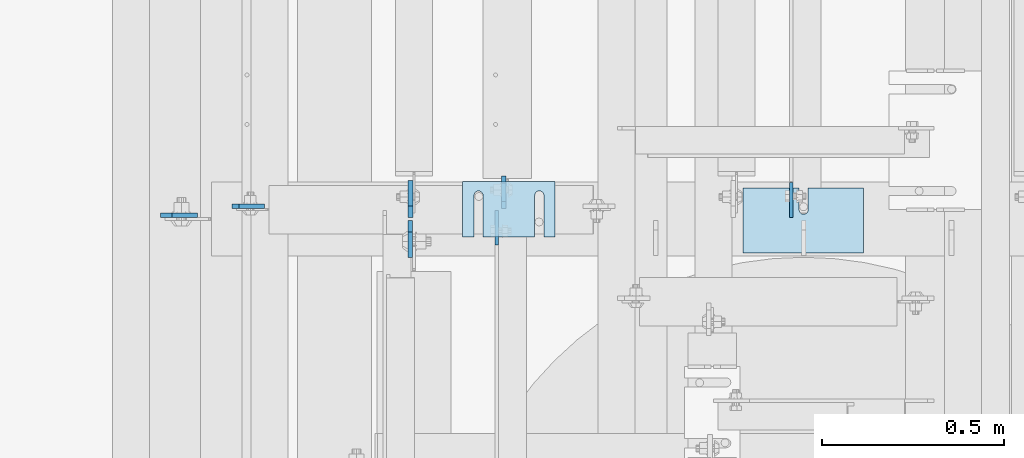
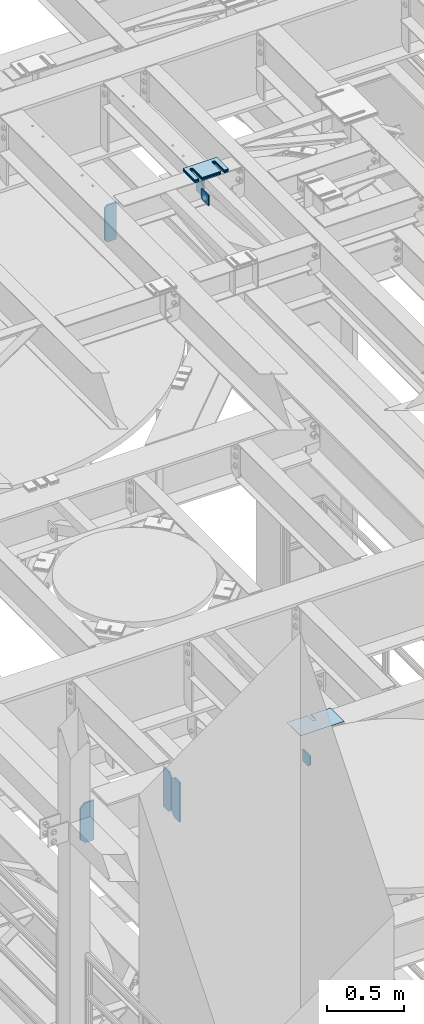
# One storey, part 1697 of 1876: 14 plates, 11 elements without a shape of their own.
"""IFC2X3 building model written with IfcOpenShell, lengths in millimetres."""

from ifc_helpers import new_model, si_unit, frame, origin_with_axes, place, context, subcontext, project, spatial, faceted_brep, material, type_object, element, aggregate, save


model = new_model("IFC2X3")

# Units and contexts
model_context = context("Model", 3, precision=1e-05, world=origin_with_axes())
body_context = subcontext(model_context, "Body", "Model", "MODEL_VIEW")
ifc_project = project(units=[si_unit("LENGTHUNIT", "METRE", prefix="MILLI"), si_unit("AREAUNIT", "SQUARE_METRE"), si_unit("VOLUMEUNIT", "CUBIC_METRE"), si_unit("MASSUNIT", "GRAM", prefix="KILO"), si_unit("TIMEUNIT", "SECOND"), si_unit("PLANEANGLEUNIT", "RADIAN"), si_unit("SOLIDANGLEUNIT", "STERADIAN"), si_unit("THERMODYNAMICTEMPERATUREUNIT", "DEGREE_CELSIUS"), si_unit("LUMINOUSINTENSITYUNIT", "LUMEN")], contexts=[model_context])

# Site, building, storey
site_placement = place(None, origin_with_axes())
site = spatial("IfcSite", under=ifc_project, at=site_placement, CompositionType="ELEMENT")
building_placement = place(site_placement, origin_with_axes())
building = spatial("IfcBuilding", under=site, at=building_placement, Name="Undefined", CompositionType="ELEMENT")
storey_placement = place(building_placement, origin_with_axes())
storey = spatial("IfcBuildingStorey", under=building, at=storey_placement, Name="Undefined", CompositionType="ELEMENT", Elevation=0.0)

# Assembly, plate
assembly_1_placement = place(storey_placement, origin_with_axes())
assembly_1 = element("IfcElementAssembly", 1, at=assembly_1_placement, inside=storey, Name="BEAM", AssemblyPlace="NOTDEFINED", PredefinedType="RIGID_FRAME")
ifc_material = material(Name="STEEL/A36")
plate_type_1 = type_object("IfcPlateType", PredefinedType="NOTDEFINED")
plate_1_placement = place(assembly_1_placement, frame((3338.51211036534, 6347.93791797889, 12976.225), z_axis=(0.0, -1.0, 0.0), x_axis=(0.0, 0.0, 1.0)))
plate_1 = element("IfcPlate", 2, at=plate_1_placement, type_object=plate_type_1, material=ifc_material, Name="PLATE", context=body_context, shape_type="Brep", body=[
    faceted_brep([(0.0, -4.76249999999982, 0.0), (0.0, -4.76249999999982, 71.7566699981689), (0.0, 4.76249999999982, 71.7566699981689), (0.0, 4.76249999999982, 0.0), (25.3999996185303, -4.76249999999982, 97.1566696166992), (25.3999996185303, 4.76249999999982, 97.1566696166992), (92.3540878295898, -4.76249999999982, 97.1566696166992), (92.3540878295898, 4.76249999999982, 97.1566696166992), (92.3540878295898, -4.76249999999982, 0.0), (92.3540878295898, 4.76249999999982, 0.0)], [[[0, 1, 2, 3]], [[1, 4, 5, 2]], [[4, 6, 7, 5]], [[6, 8, 9, 7]], [[8, 0, 3, 9]], [[5, 7, 9, 3, 2]], [[8, 6, 4, 1, 0]]]),
])

assembly_2_placement = place(storey_placement, origin_with_axes())
assembly_2 = element("IfcElementAssembly", 3, at=assembly_2_placement, inside=storey, Name="BEAM", AssemblyPlace="NOTDEFINED", PredefinedType="RIGID_FRAME")
plate_type_2 = type_object("IfcPlateType", PredefinedType="NOTDEFINED")
plate_2_placement = place(assembly_2_placement, frame((2529.26824474912, 6176.14514562684, 17784.7625), z_axis=(0.0, 0.0, 1.0), x_axis=(0.0, 1.0, 0.0)))
plate_2 = element("IfcPlate", 4, at=plate_2_placement, type_object=plate_type_2, material=ifc_material, Name="PLATE", context=body_context, shape_type="Brep", body=[
    faceted_brep([(0.0, -4.76249999999982, 0.0), (0.0, -4.76249999999982, 81.2718963623047), (0.0, 4.76249999999982, 81.2718963623047), (0.0, 4.76249999999982, 0.0), (93.8565444946289, -4.76249999999982, 81.2718963623047), (93.8565444946289, 4.76249999999982, 81.2718963623047), (93.8565444946289, -4.76249999999982, 12.6999998092651), (93.8565444946289, 4.76249999999982, 12.6999998092651), (81.1565446853638, -4.76249999999982, 0.0), (81.1565446853638, 4.76249999999982, 0.0)], [[[0, 1, 2, 3]], [[1, 4, 5, 2]], [[4, 6, 7, 5]], [[6, 8, 9, 7]], [[8, 0, 3, 9]], [[5, 7, 9, 3, 2]], [[8, 6, 4, 1, 0]]]),
])

assembly_3_placement = place(storey_placement, origin_with_axes())
assembly_3 = element("IfcElementAssembly", 5, at=assembly_3_placement, inside=storey, Name="BEAM", AssemblyPlace="NOTDEFINED", PredefinedType="RIGID_FRAME")
plate_type_3 = type_object("IfcPlateType", PredefinedType="NOTDEFINED")
plate_3_placement = place(assembly_3_placement, frame((1801.8125, 6282.7016907692, 17681.575), z_axis=(0.0, 0.0, 1.0), x_axis=(1.0, 0.0, 0.0)))
plate_3 = element("IfcPlate", 6, at=plate_3_placement, type_object=plate_type_3, material=ifc_material, Name="PLATE", context=body_context, shape_type="Brep", body=[
    faceted_brep([(0.0, -6.35000000000196, 19.0499992370605), (9.09494701772928e-13, -6.34999999999832, 273.050006866455), (-2.72848410531878e-12, 6.34999999999923, 273.050006866455), (0.0, 6.35000000000105, 19.0499992370605), (19.0499992370578, -6.35000000000696, 292.100006103516), (19.049999237056, 6.3499999999915, 292.100006103516), (88.9000015258789, -6.35000000000036, 292.100006103516), (88.9000015258789, 6.35000000000036, 292.100006103516), (88.9000015258789, -6.34999999999991, 0.0), (88.9000015258789, 6.34999999999991, 0.0), (19.0499992370642, -6.35000000000105, 0.0), (19.0499992370633, 6.35000000000105, 0.0)], [[[0, 1, 2, 3]], [[1, 4, 5, 2]], [[4, 6, 7, 5]], [[6, 8, 9, 7]], [[8, 10, 11, 9]], [[10, 0, 3, 11]], [[5, 7, 9, 11, 3, 2]], [[10, 8, 6, 4, 1, 0]]]),
])
aggregate(assembly_3, [plate_3])

# Plate
plate_4_placement = place(assembly_2_placement, frame((2548.05977180008, 6276.35197391557, 17786.35), z_axis=(0.0, 0.0, 1.0), x_axis=(-4.46050000005016e-05, 0.999999999005197, 0.0)))
plate_4 = element("IfcPlate", 7, at=plate_4_placement, type_object=plate_type_3, material=ifc_material, Name="PLATE", context=body_context, shape_type="Brep", body=[
    faceted_brep([(0.0, -6.35000000000196, 19.0499992370605), (0.0, -6.34999999999991, 169.862506866455), (0.0, 6.34999999999991, 169.862506866455), (0.0, 6.35000000000105, 19.0499992370605), (19.0499992370605, -6.34999999999991, 188.912506103516), (19.0499992370605, 6.34999999999991, 188.912506103516), (69.8500022888184, -6.34999999999991, 188.912506103516), (69.8500022888184, 6.34999999999991, 188.912506103516), (88.9000015258789, -6.34999999999991, 169.862506866455), (88.9000015258789, 6.34999999999991, 169.862506866455), (88.9000015258789, -6.34999999999991, 0.0), (88.9000015258789, 6.34999999999991, 0.0), (19.0499992370642, -6.35000000000105, 0.0), (19.0499992370633, 6.35000000000105, 0.0)], [[[0, 1, 2, 3]], [[1, 4, 5, 2]], [[4, 6, 7, 5]], [[6, 8, 9, 7]], [[8, 10, 11, 9]], [[10, 12, 13, 11]], [[12, 0, 3, 13]], [[5, 7, 9, 11, 13, 3, 2]], [[12, 10, 8, 6, 4, 1, 0]]]),
])

aggregate(assembly_2, [plate_2, plate_4])

plate_type_4 = type_object("IfcPlateType", PredefinedType="NOTDEFINED")
plate_5_placement = place(assembly_1_placement, frame((2291.55624990463, 6242.84375, 12977.8125), z_axis=(0.0, 0.0, 1.0), x_axis=(0.0, -1.0, 0.0)))
plate_5 = element("IfcPlate", 8, at=plate_5_placement, type_object=plate_type_4, material=ifc_material, Name="PLATE", context=body_context, shape_type="Brep", body=[
    faceted_brep([(0.0, -6.34999999999991, 31.75), (-1.81898940354586e-12, -6.34999999999991, 284.162506103516), (1.81898940354586e-12, 6.35000000000173, 284.162506103516), (0.0, 6.34999999999991, 31.75), (31.7499999999927, -6.34999999999991, 315.912506103516), (31.7499999999982, 6.35000000000309, 315.912506103516), (101.599998474121, -6.35000000000036, 315.912506103516), (101.599998474121, 6.35000000000036, 315.912506103516), (101.599998474121, -6.35000000000036, 0.0), (101.599998474121, 6.35000000000036, 0.0), (31.75, -6.34999999999991, 0.0), (31.75, 6.34999999999991, 0.0)], [[[0, 1, 2, 3]], [[1, 4, 5, 2]], [[4, 6, 7, 5]], [[6, 8, 9, 7]], [[8, 10, 11, 9]], [[10, 0, 3, 11]], [[5, 7, 9, 11, 3, 2]], [[10, 8, 6, 4, 1, 0]]]),
])

# Assembly, plate
assembly_4_placement = place(storey_placement, origin_with_axes())
assembly_4 = element("IfcElementAssembly", 9, at=assembly_4_placement, inside=storey, Name="BEAM", AssemblyPlace="NOTDEFINED", PredefinedType="RIGID_FRAME")
plate_6_placement = place(assembly_4_placement, frame((1605.75625, 6257.13125009537, 12974.6375), z_axis=(0.0, 0.0, 1.0), x_axis=(1.0, 0.0, 0.0)))
plate_6 = element("IfcPlate", 10, at=plate_6_placement, type_object=plate_type_4, material=ifc_material, Name="PLATE", context=body_context, shape_type="Brep", body=[
    faceted_brep([(0.0, -6.34999999999991, 31.75), (-1.81898940354586e-12, -6.34999999999991, 284.162506103516), (1.81898940354586e-12, 6.35000000000173, 284.162506103516), (0.0, 6.34999999999991, 31.75), (31.7499999999927, -6.34999999999991, 315.912506103516), (31.7499999999982, 6.35000000000309, 315.912506103516), (101.599998474121, -6.35000000000036, 315.912506103516), (101.599998474121, 6.35000000000036, 315.912506103516), (101.599998474121, -6.35000000000036, 0.0), (101.599998474121, 6.35000000000036, 0.0), (31.75, -6.34999999999991, 0.0), (31.75, 6.34999999999991, 0.0)], [[[0, 1, 2, 3]], [[1, 4, 5, 2]], [[4, 6, 7, 5]], [[6, 8, 9, 7]], [[8, 10, 11, 9]], [[10, 0, 3, 11]], [[5, 7, 9, 11, 3, 2]], [[10, 8, 6, 4, 1, 0]]]),
])
aggregate(assembly_4, [plate_6])

# Plate
plate_7_placement = place(assembly_1_placement, frame((2292.34999990463, 6250.78125, 12977.8125), z_axis=(0.0, 0.0, 1.0), x_axis=(0.0, 1.0, 0.0)))
plate_7 = element("IfcPlate", 11, at=plate_7_placement, type_object=plate_type_4, material=ifc_material, Name="PLATE", context=body_context, shape_type="Brep", body=[
    faceted_brep([(0.0, -6.34999999999991, 31.75), (-1.81898940354586e-12, -6.34999999999991, 284.162506103516), (1.81898940354586e-12, 6.35000000000173, 284.162506103516), (0.0, 6.34999999999991, 31.75), (31.7499999999927, -6.34999999999991, 315.912506103516), (31.7499999999982, 6.35000000000309, 315.912506103516), (101.599998474121, -6.35000000000036, 315.912506103516), (101.599998474121, 6.35000000000036, 315.912506103516), (101.599998474121, -6.35000000000036, 0.0), (101.599998474121, 6.35000000000036, 0.0), (31.75, -6.34999999999991, 0.0), (31.75, 6.34999999999991, 0.0)], [[[0, 1, 2, 3]], [[1, 4, 5, 2]], [[4, 6, 7, 5]], [[6, 8, 9, 7]], [[8, 10, 11, 9]], [[10, 0, 3, 11]], [[5, 7, 9, 11, 3, 2]], [[10, 8, 6, 4, 1, 0]]]),
])

aggregate(assembly_1, [plate_1, plate_5, plate_7])

# Assembly, plate
assembly_5_placement = place(storey_placement, origin_with_axes())
assembly_5 = element("IfcElementAssembly", 12, at=assembly_5_placement, inside=storey, Name="SHIM PLATE", AssemblyPlace="NOTDEFINED", PredefinedType="RIGID_FRAME")
plate_type_5 = type_object("IfcPlateType", PredefinedType="NOTDEFINED")
plate_8_placement = place(assembly_5_placement, frame((2689.6055343235, 6349.99749088431, 18009.3925), z_axis=(0.0, -1.0, 0.0), x_axis=(-1.0, 0.0, 0.0)))
plate_8 = element("IfcPlate", 13, at=plate_8_placement, type_object=plate_type_5, material=ifc_material, Name="SHIM PLATE", context=body_context, shape_type="Brep", body=[
    faceted_brep([(30.8791924037423, -0.793499999999767, 152.398895263674), (30.8814140421409, -0.793499999999767, 38.0994505407325), (30.8814140421409, 0.793499999999767, 38.0994505407325), (30.8791924037423, 0.793499999999767, 152.398895263674), (32.5828868936751, -0.793499999999767, 31.7494480341243), (32.5828868936751, 0.793499999999767, 31.7494480341243), (37.2314075583954, -0.793499999999767, 27.1009216732054), (37.2314075583954, 0.793499999999767, 27.1009216732054), (43.5814079800521, -0.793499999999767, 25.3994410405157), (43.5814079800521, 0.793499999999767, 25.3994410405157), (49.9314097200559, -0.793499999999767, 27.1009167530574), (49.9314097200559, 0.793499999999767, 27.1009167530574), (54.5799339865616, -0.793499999999767, 31.7494395121785), (54.5799339865616, 0.793499999999767, 31.7494395121785), (56.2814117582284, -0.793499999999767, 38.0994407004391), (56.2814117582284, 0.793499999999767, 38.0994407004391), (56.2791901197206, -0.793499999999767, 152.398894414155), (56.2791901197206, 0.793499999999767, 152.398895263676), (9.09494701772928e-13, -0.793499999999767, 0.0), (1.98268335225293e-05, -0.793499999999767, 152.398895263672), (1.98268335225293e-05, 0.793499999999767, 152.398895263672), (9.09494701772928e-13, 0.793499999999767, 0.0), (253.999542236328, -0.793499999999767, 6.16182660451159e-11), (253.999542236328, 0.793499999999767, 6.16182660451159e-11), (253.999557495107, -0.793499999999767, 152.398895263688), (253.999557495107, 0.793499999999767, 152.398895263688), (223.116882380463, 0.793499999999767, 152.398895263686), (223.116882380463, -0.793499999999767, 152.398895415181), (223.119104018971, 0.793499999999767, 38.0994417014649), (223.119104018971, -0.793499999999767, 38.0994417014649), (221.417626247304, 0.793499999999767, 31.7494405132047), (221.417626247304, -0.793499999999767, 31.7494405132047), (216.769101980798, 0.793499999999767, 27.1009177540836), (216.769101980798, -0.793499999999767, 27.1009177540836), (210.419100240794, 0.793499999999767, 25.399442041542), (210.419100240794, -0.793499999999767, 25.399442041542), (204.069099819138, 0.793499999999767, 27.1009226742317), (204.069099819138, -0.793499999999767, 27.1009226742317), (199.420579154417, 0.793499999999767, 31.7494490351505), (199.420579154417, -0.793499999999767, 31.7494490351505), (197.719106302883, 0.793499999999767, 38.0994515417583), (197.719106302883, -0.793499999999767, 38.0994515417583), (197.716884664484, -0.793499999999767, 152.398895263684), (197.716884664484, 0.793499999999767, 152.398895263684)], [[[0, 1, 2, 3]], [[4, 5, 2, 1]], [[6, 7, 5, 4]], [[8, 9, 7, 6]], [[10, 11, 9, 8]], [[12, 13, 11, 10]], [[14, 15, 13, 12]], [[16, 17, 15, 14]], [[18, 19, 20, 21]], [[22, 18, 21, 23]], [[24, 22, 23, 25]], [[24, 25, 26, 27]], [[27, 26, 28, 29]], [[29, 28, 30, 31]], [[31, 30, 32, 33]], [[33, 32, 34, 35]], [[35, 34, 36, 37]], [[37, 36, 38, 39]], [[39, 38, 40, 41]], [[42, 41, 40, 43]], [[12, 10, 8, 6, 4, 1, 0, 19, 18, 22, 24, 27, 29, 31, 33, 35, 37, 39, 41, 42, 16, 14]], [[20, 19, 0, 3]], [[43, 40, 38, 36, 34, 32, 30, 28, 26, 25, 23, 21, 20, 3, 2, 5, 7, 9, 11, 13, 15, 17]], [[42, 43, 17, 16]]]),
])
aggregate(assembly_5, [plate_8])

assembly_6_placement = place(storey_placement, origin_with_axes())
assembly_6 = element("IfcElementAssembly", 14, at=assembly_6_placement, inside=storey, Name="SHIM PLATE", AssemblyPlace="NOTDEFINED", PredefinedType="RIGID_FRAME")
plate_type_6 = type_object("IfcPlateType", PredefinedType="NOTDEFINED")
plate_9_placement = place(assembly_6_placement, frame((2689.6055343235, 6349.99749088454, 18007.0115), z_axis=(0.0, -1.0, 0.0), x_axis=(-1.0, 0.0, 0.0)))
plate_9 = element("IfcPlate", 15, at=plate_9_placement, type_object=plate_type_6, material=ifc_material, Name="SHIM PLATE", context=body_context, shape_type="Brep", body=[
    faceted_brep([(30.8791924037423, -1.58750000000146, 152.398895263674), (30.8814140421409, -1.58750000000146, 38.0994505407325), (30.8814140421409, 1.58750000000146, 38.0994505407325), (30.8791924037423, 1.58750000000146, 152.398895263674), (32.5828868936751, -1.58750000000146, 31.7494480341243), (32.5828868936751, 1.58750000000146, 31.7494480341243), (37.2314075583954, -1.58750000000146, 27.1009216732054), (37.2314075583954, 1.58750000000146, 27.1009216732054), (43.5814079800521, -1.58750000000146, 25.3994410405157), (43.5814079800521, 1.58750000000146, 25.3994410405157), (49.9314097200559, -1.58750000000146, 27.1009167530574), (49.9314097200559, 1.58750000000146, 27.1009167530574), (54.5799339865616, -1.58750000000146, 31.7494395121785), (54.5799339865616, 1.58750000000146, 31.7494395121785), (56.2814117582284, -1.58750000000146, 38.0994407004391), (56.2814117582284, 1.58750000000146, 38.0994407004391), (56.2791901197206, -1.58750000000146, 152.398894414155), (56.2791901197206, 1.58750000000146, 152.398895263676), (9.09494701772928e-13, -1.58750000000146, 4.54747350886464e-13), (1.98264133359771e-05, -1.58750000000146, 152.398895263672), (1.98264133359771e-05, 1.58750000000146, 152.398895263672), (9.09494701772928e-13, 1.58750000000146, 4.54747350886464e-13), (253.999542236328, -1.58750000000146, 6.16182660451159e-11), (253.999542236328, 1.58750000000146, 6.16182660451159e-11), (253.999557495107, -1.58750000000146, 152.398895263688), (253.999557495107, 1.58750000000146, 152.398895263688), (223.116882380463, 1.58750000000146, 152.398895263686), (223.116882380463, -1.58750000000146, 152.398895415181), (223.119104018971, 1.58750000000146, 38.0994417014649), (223.119104018971, -1.58750000000146, 38.0994417014649), (221.417626247304, 1.58750000000146, 31.7494405132047), (221.417626247304, -1.58750000000146, 31.7494405132047), (216.769101980798, 1.58750000000146, 27.1009177540836), (216.769101980798, -1.58750000000146, 27.1009177540836), (210.419100240794, 1.58750000000146, 25.399442041542), (210.419100240794, -1.58750000000146, 25.399442041542), (204.069099819138, 1.58750000000146, 27.1009226742317), (204.069099819138, -1.58750000000146, 27.1009226742317), (199.420579154417, 1.58750000000146, 31.7494490351505), (199.420579154417, -1.58750000000146, 31.7494490351505), (197.719106302883, 1.58750000000146, 38.0994515417583), (197.719106302883, -1.58750000000146, 38.0994515417583), (197.716884664484, -1.58750000000146, 152.398895263684), (197.716884664484, 1.58750000000146, 152.398895263684)], [[[0, 1, 2, 3]], [[4, 5, 2, 1]], [[6, 7, 5, 4]], [[8, 9, 7, 6]], [[10, 11, 9, 8]], [[12, 13, 11, 10]], [[14, 15, 13, 12]], [[16, 17, 15, 14]], [[18, 19, 20, 21]], [[22, 18, 21, 23]], [[24, 22, 23, 25]], [[24, 25, 26, 27]], [[27, 26, 28, 29]], [[29, 28, 30, 31]], [[31, 30, 32, 33]], [[33, 32, 34, 35]], [[35, 34, 36, 37]], [[37, 36, 38, 39]], [[39, 38, 40, 41]], [[42, 41, 40, 43]], [[12, 10, 8, 6, 4, 1, 0, 19, 18, 22, 24, 27, 29, 31, 33, 35, 37, 39, 41, 42, 16, 14]], [[20, 19, 0, 3]], [[43, 40, 38, 36, 34, 32, 30, 28, 26, 25, 23, 21, 20, 3, 2, 5, 7, 9, 11, 13, 15, 17]], [[42, 43, 17, 16]]]),
])
aggregate(assembly_6, [plate_9])

assembly_7_placement = place(storey_placement, origin_with_axes())
assembly_7 = element("IfcElementAssembly", 16, at=assembly_7_placement, inside=storey, Name="SHIM PLATE", AssemblyPlace="NOTDEFINED", PredefinedType="RIGID_FRAME")
plate_10_placement = place(assembly_7_placement, frame((2689.6055343235, 6349.99749088477, 18003.8365), z_axis=(0.0, -1.0, 0.0), x_axis=(-1.0, 0.0, 0.0)))
plate_10 = element("IfcPlate", 17, at=plate_10_placement, type_object=plate_type_6, material=ifc_material, Name="SHIM PLATE", context=body_context, shape_type="Brep", body=[
    faceted_brep([(30.8791924037423, -1.58750000000146, 152.398895263674), (30.8814140421409, -1.58750000000146, 38.0994505407325), (30.8814140421409, 1.58750000000146, 38.0994505407325), (30.8791924037423, 1.58750000000146, 152.398895263674), (32.5828868936751, -1.58750000000146, 31.7494480341243), (32.5828868936751, 1.58750000000146, 31.7494480341243), (37.2314075583954, -1.58750000000146, 27.1009216732054), (37.2314075583954, 1.58750000000146, 27.1009216732054), (43.5814079800521, -1.58750000000146, 25.3994410405157), (43.5814079800521, 1.58750000000146, 25.3994410405157), (49.9314097200559, -1.58750000000146, 27.1009167530574), (49.9314097200559, 1.58750000000146, 27.1009167530574), (54.5799339865616, -1.58750000000146, 31.7494395121785), (54.5799339865616, 1.58750000000146, 31.7494395121785), (56.2814117582284, -1.58750000000146, 38.0994407004391), (56.2814117582284, 1.58750000000146, 38.0994407004391), (56.2791901197206, -1.58750000000146, 152.398894414155), (56.2791901197206, 1.58750000000146, 152.398895263676), (9.09494701772928e-13, -1.58750000000146, 4.54747350886464e-13), (1.98264133359771e-05, -1.58750000000146, 152.398895263672), (1.98264133359771e-05, 1.58750000000146, 152.398895263672), (9.09494701772928e-13, 1.58750000000146, 4.54747350886464e-13), (253.999542236328, -1.58750000000146, 6.16182660451159e-11), (253.999542236328, 1.58750000000146, 6.16182660451159e-11), (253.999557495107, -1.58750000000146, 152.398895263688), (253.999557495107, 1.58750000000146, 152.398895263688), (223.116882380463, 1.58750000000146, 152.398895263686), (223.116882380463, -1.58750000000146, 152.398895415181), (223.119104018971, 1.58750000000146, 38.0994417014649), (223.119104018971, -1.58750000000146, 38.0994417014649), (221.417626247304, 1.58750000000146, 31.7494405132047), (221.417626247304, -1.58750000000146, 31.7494405132047), (216.769101980798, 1.58750000000146, 27.1009177540836), (216.769101980798, -1.58750000000146, 27.1009177540836), (210.419100240794, 1.58750000000146, 25.399442041542), (210.419100240794, -1.58750000000146, 25.399442041542), (204.069099819138, 1.58750000000146, 27.1009226742317), (204.069099819138, -1.58750000000146, 27.1009226742317), (199.420579154417, 1.58750000000146, 31.7494490351505), (199.420579154417, -1.58750000000146, 31.7494490351505), (197.719106302883, 1.58750000000146, 38.0994515417583), (197.719106302883, -1.58750000000146, 38.0994515417583), (197.716884664484, -1.58750000000146, 152.398895263684), (197.716884664484, 1.58750000000146, 152.398895263684)], [[[0, 1, 2, 3]], [[4, 5, 2, 1]], [[6, 7, 5, 4]], [[8, 9, 7, 6]], [[10, 11, 9, 8]], [[12, 13, 11, 10]], [[14, 15, 13, 12]], [[16, 17, 15, 14]], [[18, 19, 20, 21]], [[22, 18, 21, 23]], [[24, 22, 23, 25]], [[24, 25, 26, 27]], [[27, 26, 28, 29]], [[29, 28, 30, 31]], [[31, 30, 32, 33]], [[33, 32, 34, 35]], [[35, 34, 36, 37]], [[37, 36, 38, 39]], [[39, 38, 40, 41]], [[42, 41, 40, 43]], [[12, 10, 8, 6, 4, 1, 0, 19, 18, 22, 24, 27, 29, 31, 33, 35, 37, 39, 41, 42, 16, 14]], [[20, 19, 0, 3]], [[43, 40, 38, 36, 34, 32, 30, 28, 26, 25, 23, 21, 20, 3, 2, 5, 7, 9, 11, 13, 15, 17]], [[42, 43, 17, 16]]]),
])
aggregate(assembly_7, [plate_10])

assembly_8_placement = place(storey_placement, origin_with_axes())
assembly_8 = element("IfcElementAssembly", 18, at=assembly_8_placement, inside=storey, Name="SHIM PLATE", AssemblyPlace="NOTDEFINED", PredefinedType="RIGID_FRAME")
plate_type_7 = type_object("IfcPlateType", PredefinedType="NOTDEFINED")
plate_11_placement = place(assembly_8_placement, frame((2689.6055343235, 6349.997490885, 17999.868), z_axis=(0.0, -1.0, 0.0), x_axis=(-1.0, 0.0, 0.0)))
plate_11 = element("IfcPlate", 19, at=plate_11_placement, type_object=plate_type_7, material=ifc_material, Name="SHIM PLATE", context=body_context, shape_type="Brep", body=[
    faceted_brep([(30.8791924037423, -2.38100000000122, 152.398895263674), (30.8814140421409, -2.38100000000122, 38.0994505407325), (30.8814140421409, 2.38100000000122, 38.0994505407325), (30.8791924037423, 2.38100000000122, 152.398895263674), (32.5828868936751, -2.38100000000122, 31.7494480341243), (32.5828868936751, 2.38100000000122, 31.7494480341243), (37.2314075583954, -2.38100000000122, 27.1009216732054), (37.2314075583954, 2.38100000000122, 27.1009216732054), (43.5814079800521, -2.38100000000122, 25.3994410405157), (43.5814079800521, 2.38100000000122, 25.3994410405157), (49.9314097200559, -2.38100000000122, 27.1009167530574), (49.9314097200559, 2.38100000000122, 27.1009167530574), (54.5799339865616, -2.38100000000122, 31.7494395121785), (54.5799339865616, 2.38100000000122, 31.7494395121785), (56.2814117582284, -2.38100000000122, 38.0994407004391), (56.2814117582284, 2.38100000000122, 38.0994407004391), (56.2791901197206, -2.38100000000122, 152.398894414155), (56.2791901197206, 2.38100000000122, 152.398895263676), (0.0, -2.38100000000122, 4.54747350886464e-13), (1.98259931494249e-05, -2.38100000000122, 152.398895263672), (1.98259931494249e-05, 2.38100000000122, 152.398895263672), (0.0, 2.38100000000122, 4.54747350886464e-13), (253.999542236328, -2.38100000000122, 6.16182660451159e-11), (253.999542236328, 2.38100000000122, 6.16182660451159e-11), (253.999557495107, -2.38100000000122, 152.398895263688), (253.999557495107, 2.38100000000122, 152.398895263688), (223.116882380463, 2.38100000000122, 152.398895263686), (223.116882380463, -2.38100000000122, 152.398895415181), (223.119104018971, 2.38100000000122, 38.0994417014649), (223.119104018971, -2.38100000000122, 38.0994417014649), (221.417626247304, 2.38100000000122, 31.7494405132047), (221.417626247304, -2.38100000000122, 31.7494405132047), (216.769101980798, 2.38100000000122, 27.1009177540836), (216.769101980798, -2.38100000000122, 27.1009177540836), (210.419100240794, 2.38100000000122, 25.399442041542), (210.419100240794, -2.38100000000122, 25.399442041542), (204.069099819138, 2.38100000000122, 27.1009226742317), (204.069099819138, -2.38100000000122, 27.1009226742317), (199.420579154417, 2.38100000000122, 31.7494490351505), (199.420579154417, -2.38100000000122, 31.7494490351505), (197.719106302883, 2.38100000000122, 38.0994515417583), (197.719106302883, -2.38100000000122, 38.0994515417583), (197.716884664484, -2.38100000000122, 152.398895263684), (197.716884664484, 2.38100000000122, 152.398895263684)], [[[0, 1, 2, 3]], [[4, 5, 2, 1]], [[6, 7, 5, 4]], [[8, 9, 7, 6]], [[10, 11, 9, 8]], [[12, 13, 11, 10]], [[14, 15, 13, 12]], [[16, 17, 15, 14]], [[18, 19, 20, 21]], [[22, 18, 21, 23]], [[24, 22, 23, 25]], [[24, 25, 26, 27]], [[27, 26, 28, 29]], [[29, 28, 30, 31]], [[31, 30, 32, 33]], [[33, 32, 34, 35]], [[35, 34, 36, 37]], [[37, 36, 38, 39]], [[39, 38, 40, 41]], [[42, 41, 40, 43]], [[12, 10, 8, 6, 4, 1, 0, 19, 18, 22, 24, 27, 29, 31, 33, 35, 37, 39, 41, 42, 16, 14]], [[20, 19, 0, 3]], [[43, 40, 38, 36, 34, 32, 30, 28, 26, 25, 23, 21, 20, 3, 2, 5, 7, 9, 11, 13, 15, 17]], [[42, 43, 17, 16]]]),
])
aggregate(assembly_8, [plate_11])

assembly_9_placement = place(storey_placement, origin_with_axes())
assembly_9 = element("IfcElementAssembly", 20, at=assembly_9_placement, inside=storey, Name="SHIM PLATE", AssemblyPlace="NOTDEFINED", PredefinedType="RIGID_FRAME")
plate_12_placement = place(assembly_9_placement, frame((2689.6055343235, 6349.99749088523, 17995.106), z_axis=(0.0, -1.0, 0.0), x_axis=(-1.0, 0.0, 0.0)))
plate_12 = element("IfcPlate", 21, at=plate_12_placement, type_object=plate_type_7, material=ifc_material, Name="SHIM PLATE", context=body_context, shape_type="Brep", body=[
    faceted_brep([(30.8791924037423, -2.38100000000122, 152.398895263674), (30.8814140421409, -2.38100000000122, 38.0994505407325), (30.8814140421409, 2.38100000000122, 38.0994505407325), (30.8791924037423, 2.38100000000122, 152.398895263674), (32.5828868936751, -2.38100000000122, 31.7494480341243), (32.5828868936751, 2.38100000000122, 31.7494480341243), (37.2314075583954, -2.38100000000122, 27.1009216732054), (37.2314075583954, 2.38100000000122, 27.1009216732054), (43.5814079800521, -2.38100000000122, 25.3994410405157), (43.5814079800521, 2.38100000000122, 25.3994410405157), (49.9314097200559, -2.38100000000122, 27.1009167530574), (49.9314097200559, 2.38100000000122, 27.1009167530574), (54.5799339865616, -2.38100000000122, 31.7494395121785), (54.5799339865616, 2.38100000000122, 31.7494395121785), (56.2814117582284, -2.38100000000122, 38.0994407004391), (56.2814117582284, 2.38100000000122, 38.0994407004391), (56.2791901197206, -2.38100000000122, 152.398894414155), (56.2791901197206, 2.38100000000122, 152.398895263676), (0.0, -2.38100000000122, 4.54747350886464e-13), (1.98259931494249e-05, -2.38100000000122, 152.398895263672), (1.98259931494249e-05, 2.38100000000122, 152.398895263672), (0.0, 2.38100000000122, 4.54747350886464e-13), (253.999542236328, -2.38100000000122, 6.16182660451159e-11), (253.999542236328, 2.38100000000122, 6.16182660451159e-11), (253.999557495107, -2.38100000000122, 152.398895263688), (253.999557495107, 2.38100000000122, 152.398895263688), (223.116882380463, 2.38100000000122, 152.398895263686), (223.116882380463, -2.38100000000122, 152.398895415181), (223.119104018971, 2.38100000000122, 38.0994417014649), (223.119104018971, -2.38100000000122, 38.0994417014649), (221.417626247304, 2.38100000000122, 31.7494405132047), (221.417626247304, -2.38100000000122, 31.7494405132047), (216.769101980798, 2.38100000000122, 27.1009177540836), (216.769101980798, -2.38100000000122, 27.1009177540836), (210.419100240794, 2.38100000000122, 25.399442041542), (210.419100240794, -2.38100000000122, 25.399442041542), (204.069099819138, 2.38100000000122, 27.1009226742317), (204.069099819138, -2.38100000000122, 27.1009226742317), (199.420579154417, 2.38100000000122, 31.7494490351505), (199.420579154417, -2.38100000000122, 31.7494490351505), (197.719106302883, 2.38100000000122, 38.0994515417583), (197.719106302883, -2.38100000000122, 38.0994515417583), (197.716884664484, -2.38100000000122, 152.398895263684), (197.716884664484, 2.38100000000122, 152.398895263684)], [[[0, 1, 2, 3]], [[4, 5, 2, 1]], [[6, 7, 5, 4]], [[8, 9, 7, 6]], [[10, 11, 9, 8]], [[12, 13, 11, 10]], [[14, 15, 13, 12]], [[16, 17, 15, 14]], [[18, 19, 20, 21]], [[22, 18, 21, 23]], [[24, 22, 23, 25]], [[24, 25, 26, 27]], [[27, 26, 28, 29]], [[29, 28, 30, 31]], [[31, 30, 32, 33]], [[33, 32, 34, 35]], [[35, 34, 36, 37]], [[37, 36, 38, 39]], [[39, 38, 40, 41]], [[42, 41, 40, 43]], [[12, 10, 8, 6, 4, 1, 0, 19, 18, 22, 24, 27, 29, 31, 33, 35, 37, 39, 41, 42, 16, 14]], [[20, 19, 0, 3]], [[43, 40, 38, 36, 34, 32, 30, 28, 26, 25, 23, 21, 20, 3, 2, 5, 7, 9, 11, 13, 15, 17]], [[42, 43, 17, 16]]]),
])
aggregate(assembly_9, [plate_12])

assembly_10_placement = place(storey_placement, origin_with_axes())
assembly_10 = element("IfcElementAssembly", 22, at=assembly_10_placement, inside=storey, Name="SHIM PLATE", AssemblyPlace="NOTDEFINED", PredefinedType="RIGID_FRAME")
plate_type_8 = type_object("IfcPlateType", PredefinedType="NOTDEFINED")
plate_13_placement = place(assembly_10_placement, frame((2689.6055343235, 6349.99749088546, 17987.9625), z_axis=(0.0, -1.0, 0.0), x_axis=(-1.0, 0.0, 0.0)))
plate_13 = element("IfcPlate", 23, at=plate_13_placement, type_object=plate_type_8, material=ifc_material, Name="SHIM PLATE", context=body_context, shape_type="Brep", body=[
    faceted_brep([(30.8791924037423, -4.76250000000073, 152.398895263674), (30.8814140421409, -4.76250000000073, 38.0994505407325), (30.8814140421409, 4.76250000000073, 38.0994505407325), (30.8791924037423, 4.76250000000073, 152.398895263674), (32.5828868936751, -4.76250000000073, 31.7494480341243), (32.5828868936751, 4.76250000000073, 31.7494480341243), (37.2314075583954, -4.76250000000073, 27.1009216732054), (37.2314075583954, 4.76250000000073, 27.1009216732054), (43.5814079800521, -4.76250000000073, 25.3994410405157), (43.5814079800521, 4.76250000000073, 25.3994410405157), (49.9314097200559, -4.76250000000073, 27.1009167530574), (49.9314097200559, 4.76250000000073, 27.1009167530574), (54.5799339865616, -4.76250000000073, 31.7494395121785), (54.5799339865616, 4.76250000000073, 31.7494395121785), (56.2814117582284, -4.76250000000073, 38.0994407004391), (56.2814117582284, 4.76250000000073, 38.0994407004391), (56.2791901197206, -4.76250000000073, 152.398894414155), (56.2791901197206, 4.76250000000073, 152.398895263676), (0.0, -4.76249999999982, 0.0), (1.98255729628727e-05, -4.76250000000073, 152.398895263672), (1.98255729628727e-05, 4.76250000000073, 152.398895263672), (0.0, 4.76249999999982, 0.0), (253.999542236328, -4.76250000000073, 6.16182660451159e-11), (253.999542236328, 4.76250000000073, 6.16182660451159e-11), (253.999557495107, -4.76250000000073, 152.398895263688), (253.999557495107, 4.76250000000073, 152.398895263688), (223.116882380463, 4.76250000000073, 152.398895263686), (223.116882380463, -4.76250000000073, 152.398895415181), (223.119104018971, 4.76250000000073, 38.0994417014649), (223.119104018971, -4.76250000000073, 38.0994417014649), (221.417626247304, 4.76250000000073, 31.7494405132047), (221.417626247304, -4.76250000000073, 31.7494405132047), (216.769101980798, 4.76250000000073, 27.1009177540836), (216.769101980798, -4.76250000000073, 27.1009177540836), (210.419100240794, 4.76250000000073, 25.399442041542), (210.419100240794, -4.76250000000073, 25.399442041542), (204.069099819138, 4.76250000000073, 27.1009226742317), (204.069099819138, -4.76250000000073, 27.1009226742317), (199.420579154417, 4.76250000000073, 31.7494490351505), (199.420579154417, -4.76250000000073, 31.7494490351505), (197.719106302883, 4.76250000000073, 38.0994515417583), (197.719106302883, -4.76250000000073, 38.0994515417583), (197.716884664484, -4.76250000000073, 152.398895263684), (197.716884664484, 4.76250000000073, 152.398895263684)], [[[0, 1, 2, 3]], [[4, 5, 2, 1]], [[6, 7, 5, 4]], [[8, 9, 7, 6]], [[10, 11, 9, 8]], [[12, 13, 11, 10]], [[14, 15, 13, 12]], [[16, 17, 15, 14]], [[18, 19, 20, 21]], [[22, 18, 21, 23]], [[24, 22, 23, 25]], [[24, 25, 26, 27]], [[27, 26, 28, 29]], [[29, 28, 30, 31]], [[31, 30, 32, 33]], [[33, 32, 34, 35]], [[35, 34, 36, 37]], [[37, 36, 38, 39]], [[39, 38, 40, 41]], [[42, 41, 40, 43]], [[12, 10, 8, 6, 4, 1, 0, 19, 18, 22, 24, 27, 29, 31, 33, 35, 37, 39, 41, 42, 16, 14]], [[20, 19, 0, 3]], [[43, 40, 38, 36, 34, 32, 30, 28, 26, 25, 23, 21, 20, 3, 2, 5, 7, 9, 11, 13, 15, 17]], [[42, 43, 17, 16]]]),
])
aggregate(assembly_10, [plate_13])

assembly_11_placement = place(storey_placement, origin_with_axes())
assembly_11 = element("IfcElementAssembly", 24, at=assembly_11_placement, inside=storey, Name="SHIM PLATE", AssemblyPlace="NOTDEFINED", PredefinedType="RIGID_FRAME")
plate_type_9 = type_object("IfcPlateType", PredefinedType="NOTDEFINED")
plate_14_placement = place(assembly_11_placement, frame((3205.99836578369, 6154.04776696703, 13335.7925), z_axis=(1.0, 0.0, 0.0), x_axis=(0.0, 1.0, 0.0)))
plate_14 = element("IfcPlate", 25, at=plate_14_placement, type_object=plate_type_9, material=ifc_material, Name="SHIM PLATE", context=body_context, shape_type="Brep", body=[
    faceted_brep([(177.654449462891, -0.793499999999767, 153.152024232435), (177.654449462891, 0.793499999999767, 153.152024232435), (118.915740966797, 0.793499999999767, 153.152024232435), (118.915740966797, -0.793499999999767, 153.152024232435), (112.565739046814, 0.793499999999767, 154.853499989362), (112.565739046814, -0.793499999999767, 154.853499989362), (107.917214530273, 0.793499999999767, 159.502022760557), (107.917214530273, -0.793499999999767, 159.502022760557), (106.21573638916, 0.793499999999767, 165.8520240417), (106.21573638916, -0.793499999999767, 165.8520240417), (107.917214530273, 0.793499999999767, 172.202025322844), (107.917214530273, -0.793499999999767, 172.202025322844), (112.565739046813, 0.793499999999767, 176.850548094039), (112.565739046813, -0.793499999999767, 176.850548094039), (118.915740966797, 0.793499999999767, 178.552023850965), (118.915740966797, -0.793499999999767, 178.552023850965), (177.654449462891, -0.793499999999767, 178.552023850965), (177.654449462891, 0.793499999999767, 178.552023850965), (177.654449462891, -0.793499999999767, 0.0), (9.09494701772928e-13, -0.793499999999767, 0.0), (9.09494701772928e-13, 0.793499999999767, 0.0), (177.654449462891, 0.793499999999767, 0.0), (0.0, -0.793499999999767, 330.201965332031), (0.0, 0.793499999999767, 330.201965332031), (177.654449462891, -0.793499999999767, 330.201965332031), (177.654449462891, 0.793499999999767, 330.201965332031)], [[[0, 1, 2, 3]], [[3, 2, 4, 5]], [[5, 4, 6, 7]], [[7, 6, 8, 9]], [[9, 8, 10, 11]], [[11, 10, 12, 13]], [[13, 12, 14, 15]], [[16, 15, 14, 17]], [[18, 19, 20, 21]], [[19, 22, 23, 20]], [[22, 24, 25, 23]], [[25, 24, 16, 17]], [[12, 10, 8, 6, 4, 2, 1, 21, 20, 23, 25, 17, 14]], [[18, 21, 1, 0]], [[24, 22, 19, 18, 0, 3, 5, 7, 9, 11, 13, 15, 16]]]),
])
aggregate(assembly_11, [plate_14])

save(model, "model.ifc")
